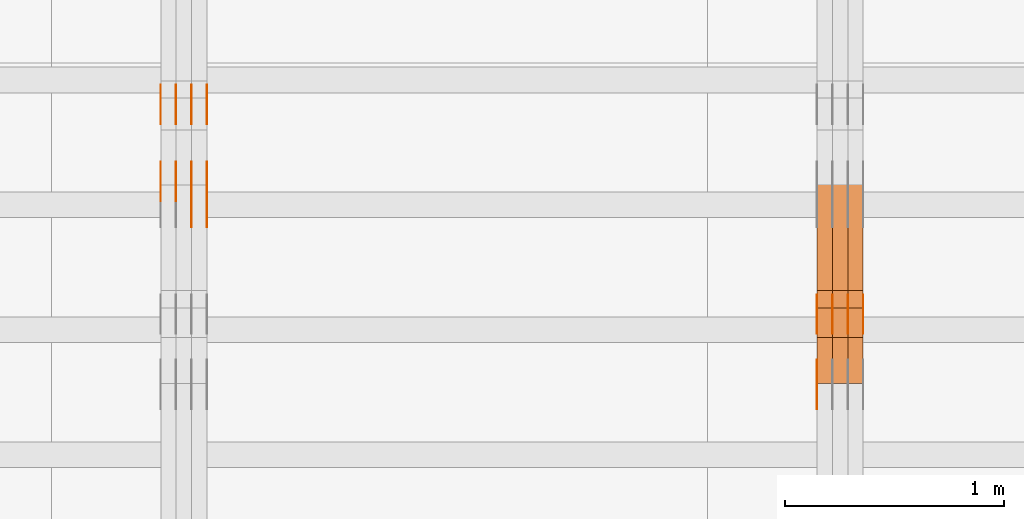
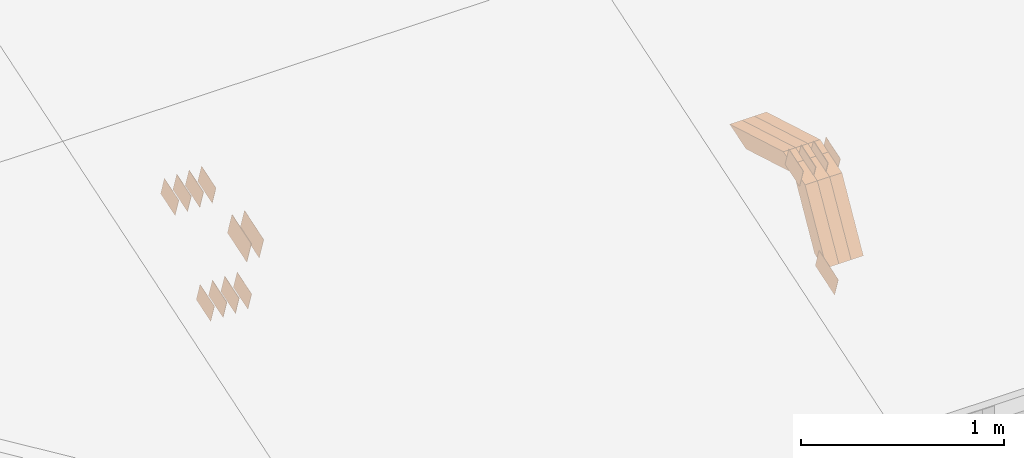
# One storey, part 249 of 385: 28 proxies.
"""IFC2X3 building model written with IfcOpenShell, lengths in millimetres."""

from ifc_helpers import new_model, entity, si_unit, converted_unit, derived_unit, direction, frame, origin, place, context, subcontext, project, spatial, polyline, outline, extrude, source, transform, mapped, material, type_object, type_shapes, element, save


model = new_model("IFC2X3")

# Units and contexts
model_context = context("Model", 3, precision=0.01, world=origin(), true_north=direction((6.12303176911189e-17, 1.0)))
body_context = subcontext(model_context, "Body", "Model", "MODEL_VIEW")
ifc_project = project(units=[si_unit("LENGTHUNIT", "METRE", prefix="MILLI"), si_unit("AREAUNIT", "SQUARE_METRE"), si_unit("VOLUMEUNIT", "CUBIC_METRE"), converted_unit("PLANEANGLEUNIT", "DEGREE", entity("IfcRatioMeasure", 0.0174532925199433), si_unit("PLANEANGLEUNIT", "RADIAN"), dimensions=[0, 0, 0, 0, 0, 0, 0]), si_unit("MASSUNIT", "GRAM", prefix="KILO"), derived_unit("MASSDENSITYUNIT", [(si_unit("MASSUNIT", "GRAM", prefix="KILO"), 1), (si_unit("LENGTHUNIT", "METRE"), -3)]), si_unit("TIMEUNIT", "SECOND"), si_unit("FREQUENCYUNIT", "HERTZ"), si_unit("THERMODYNAMICTEMPERATUREUNIT", "DEGREE_CELSIUS"), derived_unit("THERMALTRANSMITTANCEUNIT", [(si_unit("MASSUNIT", "GRAM", prefix="KILO"), 1), (si_unit("THERMODYNAMICTEMPERATUREUNIT", "KELVIN"), -1), (si_unit("TIMEUNIT", "SECOND"), -3)]), derived_unit("VOLUMETRICFLOWRATEUNIT", [(si_unit("LENGTHUNIT", "METRE"), 3), (si_unit("TIMEUNIT", "SECOND"), -1)]), si_unit("ELECTRICCURRENTUNIT", "AMPERE"), si_unit("ELECTRICVOLTAGEUNIT", "VOLT"), si_unit("POWERUNIT", "WATT"), si_unit("FORCEUNIT", "NEWTON", prefix="KILO"), si_unit("ILLUMINANCEUNIT", "LUX"), si_unit("LUMINOUSFLUXUNIT", "LUMEN"), si_unit("LUMINOUSINTENSITYUNIT", "CANDELA"), derived_unit("USERDEFINED", [(si_unit("MASSUNIT", "GRAM", prefix="KILO"), -1), (si_unit("LENGTHUNIT", "METRE"), -2), (si_unit("TIMEUNIT", "SECOND"), 3), (si_unit("LUMINOUSFLUXUNIT", "LUMEN"), 1)]), derived_unit("LINEARVELOCITYUNIT", [(si_unit("LENGTHUNIT", "METRE"), 1), (si_unit("TIMEUNIT", "SECOND"), -1)]), si_unit("PRESSUREUNIT", "PASCAL"), derived_unit("USERDEFINED", [(si_unit("LENGTHUNIT", "METRE"), -2), (si_unit("MASSUNIT", "GRAM", prefix="KILO"), 1), (si_unit("TIMEUNIT", "SECOND"), -2)])], contexts=[model_context])

# Site, building, storey
site_placement = place(None, origin())
site = spatial("IfcSite", under=ifc_project, at=site_placement, CompositionType="ELEMENT")
building_placement = place(site_placement, origin())
building = spatial("IfcBuilding", under=site, at=building_placement, CompositionType="ELEMENT")
storey_placement = place(building_placement, origin())
storey = spatial("IfcBuildingStorey", under=building, at=storey_placement, Name="Default", CompositionType="ELEMENT", Elevation=0.0)

# Proxies
ifc_material_1 = material(Name="IfcSurfaceStyle #477129")
building_element_proxy_type_1 = type_object("IfcBuildingElementProxyType", PredefinedType="NOTDEFINED", material=ifc_material_1)
shared_shape_1 = source(origin(), body_context, "Body", "SweptSolid", [
    extrude(outline(polyline([(-99.9998204243802, -60.000067376167), (99.9998338462265, -60.000067376167), (99.9998204243802, 60.000067376167), (-99.9998338462265, 60.000067376167), (-99.9998204243802, -60.000067376167)])), frame((100.000602015329, 60.0001864986889, 0.0), z_axis=(0.0, 0.0, 1.0), x_axis=(-1.0, 0.0, 0.0)), (0.0, 0.0, 1.0), 1.29999999999999),
])
type_shapes(building_element_proxy_type_1, [shared_shape_1])
proxy_1_placement = place(building_placement, frame((39175.0, 4114.85465165112, 513.097031388771), z_axis=(-1.0, 0.0, 0.0), x_axis=(0.0, 0.951056516295124, 0.309016994375039)))
element("IfcBuildingElementProxy", 1, at=proxy_1_placement, inside=storey, type_object=building_element_proxy_type_1, material=ifc_material_1, context=body_context, shape_type="MappedRepresentation", body=[
    mapped(shared_shape_1, transform((0.0, 0.0, 0.0), scale=1.0)),
])
ifc_material_2 = material(Name="IfcSurfaceStyle #470232")
building_element_proxy_type_2 = type_object("IfcBuildingElementProxyType", PredefinedType="NOTDEFINED", material=ifc_material_2)
shared_shape_2 = source(origin(), body_context, "Body", "SweptSolid", [
    extrude(outline(polyline([(-74.999865998172, -60.0000306612919), (74.999869989555, -60.0000306612919), (74.999865998172, 60.0000306612919), (-74.999869989555, 60.0000306612919), (-74.999865998172, -60.0000306612919)])), frame((75.0006726017528, 60.0001996460842, 0.0), z_axis=(0.0, 0.0, 1.0), x_axis=(-1.0, 0.0, 0.0)), (0.0, 0.0, 1.0), 1.3),
])
type_shapes(building_element_proxy_type_2, [shared_shape_2])
proxy_2_placement = place(building_placement, frame((39386.3, 4460.38978242656, 957.314497110567), z_axis=(-1.0, 0.0, 0.0), x_axis=(0.0, 0.951056516295154, 0.309016994374948)))
element("IfcBuildingElementProxy", 2, at=proxy_2_placement, inside=storey, type_object=building_element_proxy_type_2, material=ifc_material_2, context=body_context, shape_type="MappedRepresentation", body=[
    mapped(shared_shape_2, transform((0.0, 0.0, 0.0), scale=1.0)),
])
ifc_material_3 = material(Name="IfcSurfaceStyle #470175")
building_element_proxy_type_3 = type_object("IfcBuildingElementProxyType", PredefinedType="NOTDEFINED", material=ifc_material_3)
shared_shape_3 = source(origin(), body_context, "Body", "SweptSolid", [
    extrude(outline(polyline([(-74.999865998172, -60.0000306612919), (74.999869989555, -60.0000306612919), (74.999865998172, 60.0000306612919), (-74.999869989555, 60.0000306612919), (-74.999865998172, -60.0000306612919)])), frame((75.0006726017528, 60.0001996460842, 0.0), z_axis=(0.0, 0.0, 1.0), x_axis=(-1.0, 0.0, 0.0)), (0.0, 0.0, 1.0), 1.3),
])
type_shapes(building_element_proxy_type_3, [shared_shape_3])
proxy_3_placement = place(building_placement, frame((39315.0, 4460.38978242656, 957.314497110567), z_axis=(-1.0, 0.0, 0.0), x_axis=(0.0, 0.951056516295154, 0.309016994374948)))
element("IfcBuildingElementProxy", 3, at=proxy_3_placement, inside=storey, type_object=building_element_proxy_type_3, material=ifc_material_3, context=body_context, shape_type="MappedRepresentation", body=[
    mapped(shared_shape_3, transform((0.0, 0.0, 0.0), scale=1.0)),
])
ifc_material_4 = material(Name="IfcSurfaceStyle #470118")
building_element_proxy_type_4 = type_object("IfcBuildingElementProxyType", PredefinedType="NOTDEFINED", material=ifc_material_4)
shared_shape_4 = source(origin(), body_context, "Body", "SweptSolid", [
    extrude(outline(polyline([(-74.999865998172, -60.0000306612919), (74.999869989555, -60.0000306612919), (74.999865998172, 60.0000306612919), (-74.999869989555, 60.0000306612919), (-74.999865998172, -60.0000306612919)])), frame((75.0006726017528, 60.0001996460842, 0.0), z_axis=(0.0, 0.0, 1.0), x_axis=(-1.0, 0.0, 0.0)), (0.0, 0.0, 1.0), 1.3),
])
type_shapes(building_element_proxy_type_4, [shared_shape_4])
proxy_4_placement = place(building_placement, frame((39316.3, 4460.38978242656, 957.314497110567), z_axis=(-1.0, 0.0, 0.0), x_axis=(0.0, 0.951056516295154, 0.309016994374948)))
element("IfcBuildingElementProxy", 4, at=proxy_4_placement, inside=storey, type_object=building_element_proxy_type_4, material=ifc_material_4, context=body_context, shape_type="MappedRepresentation", body=[
    mapped(shared_shape_4, transform((0.0, 0.0, 0.0), scale=1.0)),
])
ifc_material_5 = material(Name="IfcSurfaceStyle #470061")
building_element_proxy_type_5 = type_object("IfcBuildingElementProxyType", PredefinedType="NOTDEFINED", material=ifc_material_5)
shared_shape_5 = source(origin(), body_context, "Body", "SweptSolid", [
    extrude(outline(polyline([(-74.999865998172, -60.0000306612919), (74.999869989555, -60.0000306612919), (74.999865998172, 60.0000306612919), (-74.999869989555, 60.0000306612919), (-74.999865998172, -60.0000306612919)])), frame((75.0006726017528, 60.0001996460842, 0.0), z_axis=(0.0, 0.0, 1.0), x_axis=(-1.0, 0.0, 0.0)), (0.0, 0.0, 1.0), 1.29999999999999),
])
type_shapes(building_element_proxy_type_5, [shared_shape_5])
proxy_5_placement = place(building_placement, frame((39245.0, 4460.38978242656, 957.314497110567), z_axis=(-1.0, 0.0, 0.0), x_axis=(0.0, 0.951056516295154, 0.309016994374948)))
element("IfcBuildingElementProxy", 5, at=proxy_5_placement, inside=storey, type_object=building_element_proxy_type_5, material=ifc_material_5, context=body_context, shape_type="MappedRepresentation", body=[
    mapped(shared_shape_5, transform((0.0, 0.0, 0.0), scale=1.0)),
])
ifc_material_6 = material(Name="IfcSurfaceStyle #470004")
building_element_proxy_type_6 = type_object("IfcBuildingElementProxyType", PredefinedType="NOTDEFINED", material=ifc_material_6)
shared_shape_6 = source(origin(), body_context, "Body", "SweptSolid", [
    extrude(outline(polyline([(-74.999865998172, -60.0000306612919), (74.999869989555, -60.0000306612919), (74.999865998172, 60.0000306612919), (-74.999869989555, 60.0000306612919), (-74.999865998172, -60.0000306612919)])), frame((75.0006726017528, 60.0001996460842, 0.0), z_axis=(0.0, 0.0, 1.0), x_axis=(-1.0, 0.0, 0.0)), (0.0, 0.0, 1.0), 1.29999999999999),
])
type_shapes(building_element_proxy_type_6, [shared_shape_6])
proxy_6_placement = place(building_placement, frame((39246.3, 4460.38978242656, 957.314497110567), z_axis=(-1.0, 0.0, 0.0), x_axis=(0.0, 0.951056516295154, 0.309016994374948)))
element("IfcBuildingElementProxy", 6, at=proxy_6_placement, inside=storey, type_object=building_element_proxy_type_6, material=ifc_material_6, context=body_context, shape_type="MappedRepresentation", body=[
    mapped(shared_shape_6, transform((0.0, 0.0, 0.0), scale=1.0)),
])
ifc_material_7 = material(Name="IfcSurfaceStyle #469947")
building_element_proxy_type_7 = type_object("IfcBuildingElementProxyType", PredefinedType="NOTDEFINED", material=ifc_material_7)
shared_shape_7 = source(origin(), body_context, "Body", "SweptSolid", [
    extrude(outline(polyline([(-74.999865998172, -60.0000306612919), (74.999869989555, -60.0000306612919), (74.999865998172, 60.0000306612919), (-74.999869989555, 60.0000306612919), (-74.999865998172, -60.0000306612919)])), frame((75.0006726017528, 60.0001996460842, 0.0), z_axis=(0.0, 0.0, 1.0), x_axis=(-1.0, 0.0, 0.0)), (0.0, 0.0, 1.0), 1.29999999999999),
])
type_shapes(building_element_proxy_type_7, [shared_shape_7])
proxy_7_placement = place(building_placement, frame((39175.0, 4460.38978242656, 957.314497110567), z_axis=(-1.0, 0.0, 0.0), x_axis=(0.0, 0.951056516295154, 0.309016994374948)))
element("IfcBuildingElementProxy", 7, at=proxy_7_placement, inside=storey, type_object=building_element_proxy_type_7, material=ifc_material_7, context=body_context, shape_type="MappedRepresentation", body=[
    mapped(shared_shape_7, transform((0.0, 0.0, 0.0), scale=1.0)),
])
ifc_material_8 = material(Name="IfcSurfaceStyle #457704")
building_element_proxy_type_8 = type_object("IfcBuildingElementProxyType", Name="T1-W12 457702", PredefinedType="NOTDEFINED", material=ifc_material_8)
shared_shape_8 = source(origin(), body_context, "Body", "SweptSolid", [
    extrude(outline(polyline([(-249.405625983165, -47.5001691155616), (243.345753908996, -47.5001691155616), (232.115534842595, 2.39993474701938e-05), (162.527010966644, 47.5001571158879), (-388.58267373507, 47.5001571158879), (-249.405625983165, -47.5001691155616)])), frame((243.345867653852, 47.5001571158879, 0.0), z_axis=(0.0, 0.0, 1.0), x_axis=(-1.0, 0.0, 0.0)), (0.0, 0.0, 1.0), 70.0),
])
type_shapes(building_element_proxy_type_8, [shared_shape_8])
proxy_8_placement = place(building_placement, frame((39385.0, 4581.32698473632, 976.172276753357), z_axis=(-1.0, 0.0, 0.0), x_axis=(0.0, 0.959722067881787, -0.280951156645966)))
element("IfcBuildingElementProxy", 8, at=proxy_8_placement, inside=storey, type_object=building_element_proxy_type_8, material=ifc_material_8, Name="T1-W12", context=body_context, shape_type="MappedRepresentation", body=[
    mapped(shared_shape_8, transform((0.0, 0.0, 0.0), scale=1.0)),
])
ifc_material_9 = material(Name="IfcSurfaceStyle #457638")
building_element_proxy_type_9 = type_object("IfcBuildingElementProxyType", Name="T1-W12 457636", PredefinedType="NOTDEFINED", material=ifc_material_9)
shared_shape_9 = source(origin(), body_context, "Body", "SweptSolid", [
    extrude(outline(polyline([(-249.405625983165, -47.5001691155616), (243.345753908996, -47.5001691155616), (232.115534842595, 2.39993474701938e-05), (162.527010966644, 47.5001571158879), (-388.58267373507, 47.5001571158879), (-249.405625983165, -47.5001691155616)])), frame((243.345867653852, 47.5001571158879, 0.0), z_axis=(0.0, 0.0, 1.0), x_axis=(-1.0, 0.0, 0.0)), (0.0, 0.0, 1.0), 70.0),
])
type_shapes(building_element_proxy_type_9, [shared_shape_9])
proxy_9_placement = place(building_placement, frame((39315.0, 4581.32698473632, 976.172276753357), z_axis=(-1.0, 0.0, 0.0), x_axis=(0.0, 0.959722067881787, -0.280951156645966)))
element("IfcBuildingElementProxy", 9, at=proxy_9_placement, inside=storey, type_object=building_element_proxy_type_9, material=ifc_material_9, Name="T1-W12", context=body_context, shape_type="MappedRepresentation", body=[
    mapped(shared_shape_9, transform((0.0, 0.0, 0.0), scale=1.0)),
])
ifc_material_10 = material(Name="IfcSurfaceStyle #457572")
building_element_proxy_type_10 = type_object("IfcBuildingElementProxyType", Name="T1-W12 457570", PredefinedType="NOTDEFINED", material=ifc_material_10)
shared_shape_10 = source(origin(), body_context, "Body", "SweptSolid", [
    extrude(outline(polyline([(-249.405625983165, -47.5001691155616), (243.345753908996, -47.5001691155616), (232.115534842595, 2.39993474701938e-05), (162.527010966644, 47.5001571158879), (-388.58267373507, 47.5001571158879), (-249.405625983165, -47.5001691155616)])), frame((243.345867653852, 47.5001571158879, 0.0), z_axis=(0.0, 0.0, 1.0), x_axis=(-1.0, 0.0, 0.0)), (0.0, 0.0, 1.0), 70.0),
])
type_shapes(building_element_proxy_type_10, [shared_shape_10])
proxy_10_placement = place(building_placement, frame((39245.0, 4581.32698473632, 976.172276753357), z_axis=(-1.0, 0.0, 0.0), x_axis=(0.0, 0.959722067881787, -0.280951156645966)))
element("IfcBuildingElementProxy", 10, at=proxy_10_placement, inside=storey, type_object=building_element_proxy_type_10, material=ifc_material_10, Name="T1-W12", context=body_context, shape_type="MappedRepresentation", body=[
    mapped(shared_shape_10, transform((0.0, 0.0, 0.0), scale=1.0)),
])
ifc_material_11 = material(Name="IfcSurfaceStyle #457308")
building_element_proxy_type_11 = type_object("IfcBuildingElementProxyType", Name="T1-W27 457306", PredefinedType="NOTDEFINED", material=ifc_material_11)
shared_shape_11 = source(origin(), body_context, "Body", "SweptSolid", [
    extrude(outline(polyline([(-321.979763159708, -47.49993999164), (138.960018341432, -47.49993999164), (191.013775341887, -0.000473170132329126), (209.87827169492, 47.5001765767061), (-217.872302218531, 47.5001765767062), (-321.979763159708, -47.49993999164)])), frame((209.87827169492, 47.5001765767061, 0.0), z_axis=(0.0, 0.0, 1.0), x_axis=(-1.0, 0.0, 0.0)), (0.0, 0.0, 1.0), 70.0),
])
type_shapes(building_element_proxy_type_11, [shared_shape_11])
proxy_11_placement = place(building_placement, frame((39385.0, 4233.3125, 512.021728515625), z_axis=(-1.0, 0.0, 0.0), x_axis=(0.0, 0.494231057369727, 0.869330582650352)))
element("IfcBuildingElementProxy", 11, at=proxy_11_placement, inside=storey, type_object=building_element_proxy_type_11, material=ifc_material_11, Name="T1-W27", context=body_context, shape_type="MappedRepresentation", body=[
    mapped(shared_shape_11, transform((0.0, 0.0, 0.0), scale=1.0)),
])
ifc_material_12 = material(Name="IfcSurfaceStyle #457242")
building_element_proxy_type_12 = type_object("IfcBuildingElementProxyType", Name="T1-W27 457240", PredefinedType="NOTDEFINED", material=ifc_material_12)
shared_shape_12 = source(origin(), body_context, "Body", "SweptSolid", [
    extrude(outline(polyline([(-321.979763159708, -47.49993999164), (138.960018341432, -47.49993999164), (191.013775341887, -0.000473170132329126), (209.87827169492, 47.5001765767061), (-217.872302218531, 47.5001765767062), (-321.979763159708, -47.49993999164)])), frame((209.87827169492, 47.5001765767061, 0.0), z_axis=(0.0, 0.0, 1.0), x_axis=(-1.0, 0.0, 0.0)), (0.0, 0.0, 1.0), 70.0),
])
type_shapes(building_element_proxy_type_12, [shared_shape_12])
proxy_12_placement = place(building_placement, frame((39315.0, 4233.3125, 512.021728515625), z_axis=(-1.0, 0.0, 0.0), x_axis=(0.0, 0.494231057369727, 0.869330582650352)))
element("IfcBuildingElementProxy", 12, at=proxy_12_placement, inside=storey, type_object=building_element_proxy_type_12, material=ifc_material_12, Name="T1-W27", context=body_context, shape_type="MappedRepresentation", body=[
    mapped(shared_shape_12, transform((0.0, 0.0, 0.0), scale=1.0)),
])
ifc_material_13 = material(Name="IfcSurfaceStyle #457176")
building_element_proxy_type_13 = type_object("IfcBuildingElementProxyType", Name="T1-W27 457174", PredefinedType="NOTDEFINED", material=ifc_material_13)
shared_shape_13 = source(origin(), body_context, "Body", "SweptSolid", [
    extrude(outline(polyline([(-321.979763159708, -47.49993999164), (138.960018341432, -47.49993999164), (191.013775341887, -0.000473170132329126), (209.87827169492, 47.5001765767061), (-217.872302218531, 47.5001765767062), (-321.979763159708, -47.49993999164)])), frame((209.87827169492, 47.5001765767061, 0.0), z_axis=(0.0, 0.0, 1.0), x_axis=(-1.0, 0.0, 0.0)), (0.0, 0.0, 1.0), 70.0),
])
type_shapes(building_element_proxy_type_13, [shared_shape_13])
proxy_13_placement = place(building_placement, frame((39245.0, 4233.3125, 512.021728515625), z_axis=(-1.0, 0.0, 0.0), x_axis=(0.0, 0.494231057369727, 0.869330582650352)))
element("IfcBuildingElementProxy", 13, at=proxy_13_placement, inside=storey, type_object=building_element_proxy_type_13, material=ifc_material_13, Name="T1-W27", context=body_context, shape_type="MappedRepresentation", body=[
    mapped(shared_shape_13, transform((0.0, 0.0, 0.0), scale=1.0)),
])
ifc_material_14 = material(Name="IfcSurfaceStyle #442640")
building_element_proxy_type_14 = type_object("IfcBuildingElementProxyType", PredefinedType="NOTDEFINED", material=ifc_material_14)
shared_shape_14 = source(origin(), body_context, "Body", "SweptSolid", [
    extrude(outline(polyline([(-74.9998707133927, -60.0000596852269), (74.9998841352353, -60.0000596852269), (74.999861282944, 60.0000596852269), (-74.9998747047866, 60.0000596852269), (-74.9998707133927, -60.0000596852269)])), frame((74.9998841352353, 60.0000596852269, 0.0), z_axis=(0.0, 0.0, 1.0), x_axis=(-1.0, 0.0, 0.0)), (0.0, 0.0, 1.0), 1.3),
])
type_shapes(building_element_proxy_type_14, [shared_shape_14])
proxy_14_placement = place(building_placement, frame((36386.3, 5067.4882362875, 826.131473120182), z_axis=(-1.0, 0.0, 0.0), x_axis=(0.0, 0.951056516295124, 0.309016994375039)))
element("IfcBuildingElementProxy", 14, at=proxy_14_placement, inside=storey, type_object=building_element_proxy_type_14, material=ifc_material_14, context=body_context, shape_type="MappedRepresentation", body=[
    mapped(shared_shape_14, transform((0.0, 0.0, 0.0), scale=1.0)),
])
ifc_material_15 = material(Name="IfcSurfaceStyle #442583")
building_element_proxy_type_15 = type_object("IfcBuildingElementProxyType", PredefinedType="NOTDEFINED", material=ifc_material_15)
shared_shape_15 = source(origin(), body_context, "Body", "SweptSolid", [
    extrude(outline(polyline([(-74.9998707133927, -60.0000596852269), (74.9998841352353, -60.0000596852269), (74.999861282944, 60.0000596852269), (-74.9998747047866, 60.0000596852269), (-74.9998707133927, -60.0000596852269)])), frame((74.9998841352353, 60.0000596852269, 0.0), z_axis=(0.0, 0.0, 1.0), x_axis=(-1.0, 0.0, 0.0)), (0.0, 0.0, 1.0), 1.3),
])
type_shapes(building_element_proxy_type_15, [shared_shape_15])
proxy_15_placement = place(building_placement, frame((36315.0, 5067.4882362875, 826.131473120182), z_axis=(-1.0, 0.0, 0.0), x_axis=(0.0, 0.951056516295124, 0.309016994375039)))
element("IfcBuildingElementProxy", 15, at=proxy_15_placement, inside=storey, type_object=building_element_proxy_type_15, material=ifc_material_15, context=body_context, shape_type="MappedRepresentation", body=[
    mapped(shared_shape_15, transform((0.0, 0.0, 0.0), scale=1.0)),
])
ifc_material_16 = material(Name="IfcSurfaceStyle #442526")
building_element_proxy_type_16 = type_object("IfcBuildingElementProxyType", PredefinedType="NOTDEFINED", material=ifc_material_16)
shared_shape_16 = source(origin(), body_context, "Body", "SweptSolid", [
    extrude(outline(polyline([(-74.9998707133927, -60.0000596852269), (74.9998841352353, -60.0000596852269), (74.999861282944, 60.0000596852269), (-74.9998747047866, 60.0000596852269), (-74.9998707133927, -60.0000596852269)])), frame((74.9998841352353, 60.0000596852269, 0.0), z_axis=(0.0, 0.0, 1.0), x_axis=(-1.0, 0.0, 0.0)), (0.0, 0.0, 1.0), 1.3),
])
type_shapes(building_element_proxy_type_16, [shared_shape_16])
proxy_16_placement = place(building_placement, frame((36316.3, 5067.4882362875, 826.131473120182), z_axis=(-1.0, 0.0, 0.0), x_axis=(0.0, 0.951056516295124, 0.309016994375039)))
element("IfcBuildingElementProxy", 16, at=proxy_16_placement, inside=storey, type_object=building_element_proxy_type_16, material=ifc_material_16, context=body_context, shape_type="MappedRepresentation", body=[
    mapped(shared_shape_16, transform((0.0, 0.0, 0.0), scale=1.0)),
])
ifc_material_17 = material(Name="IfcSurfaceStyle #442469")
building_element_proxy_type_17 = type_object("IfcBuildingElementProxyType", PredefinedType="NOTDEFINED", material=ifc_material_17)
shared_shape_17 = source(origin(), body_context, "Body", "SweptSolid", [
    extrude(outline(polyline([(-74.9998707133927, -60.0000596852269), (74.9998841352353, -60.0000596852269), (74.999861282944, 60.0000596852269), (-74.9998747047866, 60.0000596852269), (-74.9998707133927, -60.0000596852269)])), frame((74.9998841352353, 60.0000596852269, 0.0), z_axis=(0.0, 0.0, 1.0), x_axis=(-1.0, 0.0, 0.0)), (0.0, 0.0, 1.0), 1.29999999999999),
])
type_shapes(building_element_proxy_type_17, [shared_shape_17])
proxy_17_placement = place(building_placement, frame((36245.0, 5067.4882362875, 826.131473120182), z_axis=(-1.0, 0.0, 0.0), x_axis=(0.0, 0.951056516295124, 0.309016994375039)))
element("IfcBuildingElementProxy", 17, at=proxy_17_placement, inside=storey, type_object=building_element_proxy_type_17, material=ifc_material_17, context=body_context, shape_type="MappedRepresentation", body=[
    mapped(shared_shape_17, transform((0.0, 0.0, 0.0), scale=1.0)),
])
ifc_material_18 = material(Name="IfcSurfaceStyle #442412")
building_element_proxy_type_18 = type_object("IfcBuildingElementProxyType", PredefinedType="NOTDEFINED", material=ifc_material_18)
shared_shape_18 = source(origin(), body_context, "Body", "SweptSolid", [
    extrude(outline(polyline([(-74.9998707133927, -60.0000596852269), (74.9998841352353, -60.0000596852269), (74.999861282944, 60.0000596852269), (-74.9998747047866, 60.0000596852269), (-74.9998707133927, -60.0000596852269)])), frame((74.9998841352353, 60.0000596852269, 0.0), z_axis=(0.0, 0.0, 1.0), x_axis=(-1.0, 0.0, 0.0)), (0.0, 0.0, 1.0), 1.29999999999999),
])
type_shapes(building_element_proxy_type_18, [shared_shape_18])
proxy_18_placement = place(building_placement, frame((36246.3, 5067.4882362875, 826.131473120182), z_axis=(-1.0, 0.0, 0.0), x_axis=(0.0, 0.951056516295124, 0.309016994375039)))
element("IfcBuildingElementProxy", 18, at=proxy_18_placement, inside=storey, type_object=building_element_proxy_type_18, material=ifc_material_18, context=body_context, shape_type="MappedRepresentation", body=[
    mapped(shared_shape_18, transform((0.0, 0.0, 0.0), scale=1.0)),
])
ifc_material_19 = material(Name="IfcSurfaceStyle #442355")
building_element_proxy_type_19 = type_object("IfcBuildingElementProxyType", PredefinedType="NOTDEFINED", material=ifc_material_19)
shared_shape_19 = source(origin(), body_context, "Body", "SweptSolid", [
    extrude(outline(polyline([(-74.9998707133927, -60.0000596852269), (74.9998841352353, -60.0000596852269), (74.999861282944, 60.0000596852269), (-74.9998747047866, 60.0000596852269), (-74.9998707133927, -60.0000596852269)])), frame((74.9998841352353, 60.0000596852269, 0.0), z_axis=(0.0, 0.0, 1.0), x_axis=(-1.0, 0.0, 0.0)), (0.0, 0.0, 1.0), 1.29999999999999),
])
type_shapes(building_element_proxy_type_19, [shared_shape_19])
proxy_19_placement = place(building_placement, frame((36175.0, 5067.4882362875, 826.131473120182), z_axis=(-1.0, 0.0, 0.0), x_axis=(0.0, 0.951056516295124, 0.309016994375039)))
element("IfcBuildingElementProxy", 19, at=proxy_19_placement, inside=storey, type_object=building_element_proxy_type_19, material=ifc_material_19, context=body_context, shape_type="MappedRepresentation", body=[
    mapped(shared_shape_19, transform((0.0, 0.0, 0.0), scale=1.0)),
])
ifc_material_20 = material(Name="IfcSurfaceStyle #436826")
building_element_proxy_type_20 = type_object("IfcBuildingElementProxyType", PredefinedType="NOTDEFINED", material=ifc_material_20)
shared_shape_20 = source(origin(), body_context, "Body", "SweptSolid", [
    extrude(outline(polyline([(-74.9998565677224, -60.0000596852342), (74.9998794200083, -60.0000596852342), (74.9998565677242, 60.0000596852342), (-74.9998794200101, 60.0000596852342), (-74.9998565677224, -60.0000596852342)])), frame((74.9998794200083, 60.0000596852342, 0.0), z_axis=(0.0, 0.0, 1.0), x_axis=(-1.0, 0.0, 0.0)), (0.0, 0.0, 1.0), 1.3),
])
type_shapes(building_element_proxy_type_20, [shared_shape_20])
proxy_20_placement = place(building_placement, frame((36386.3, 5418.6991737875, 1250.81341892098), z_axis=(-1.0, 0.0, 0.0), x_axis=(0.0, 0.951056516295154, 0.309016994374948)))
element("IfcBuildingElementProxy", 20, at=proxy_20_placement, inside=storey, type_object=building_element_proxy_type_20, material=ifc_material_20, context=body_context, shape_type="MappedRepresentation", body=[
    mapped(shared_shape_20, transform((0.0, 0.0, 0.0), scale=1.0)),
])
ifc_material_21 = material(Name="IfcSurfaceStyle #436769")
building_element_proxy_type_21 = type_object("IfcBuildingElementProxyType", PredefinedType="NOTDEFINED", material=ifc_material_21)
shared_shape_21 = source(origin(), body_context, "Body", "SweptSolid", [
    extrude(outline(polyline([(-74.9998565677224, -60.0000596852342), (74.9998794200083, -60.0000596852342), (74.9998565677242, 60.0000596852342), (-74.9998794200101, 60.0000596852342), (-74.9998565677224, -60.0000596852342)])), frame((74.9998794200083, 60.0000596852342, 0.0), z_axis=(0.0, 0.0, 1.0), x_axis=(-1.0, 0.0, 0.0)), (0.0, 0.0, 1.0), 1.3),
])
type_shapes(building_element_proxy_type_21, [shared_shape_21])
proxy_21_placement = place(building_placement, frame((36315.0, 5418.6991737875, 1250.81341892098), z_axis=(-1.0, 0.0, 0.0), x_axis=(0.0, 0.951056516295154, 0.309016994374948)))
element("IfcBuildingElementProxy", 21, at=proxy_21_placement, inside=storey, type_object=building_element_proxy_type_21, material=ifc_material_21, context=body_context, shape_type="MappedRepresentation", body=[
    mapped(shared_shape_21, transform((0.0, 0.0, 0.0), scale=1.0)),
])
ifc_material_22 = material(Name="IfcSurfaceStyle #436712")
building_element_proxy_type_22 = type_object("IfcBuildingElementProxyType", PredefinedType="NOTDEFINED", material=ifc_material_22)
shared_shape_22 = source(origin(), body_context, "Body", "SweptSolid", [
    extrude(outline(polyline([(-74.9998565677224, -60.0000596852342), (74.9998794200083, -60.0000596852342), (74.9998565677242, 60.0000596852342), (-74.9998794200101, 60.0000596852342), (-74.9998565677224, -60.0000596852342)])), frame((74.9998794200083, 60.0000596852342, 0.0), z_axis=(0.0, 0.0, 1.0), x_axis=(-1.0, 0.0, 0.0)), (0.0, 0.0, 1.0), 1.3),
])
type_shapes(building_element_proxy_type_22, [shared_shape_22])
proxy_22_placement = place(building_placement, frame((36316.3, 5418.6991737875, 1250.81341892098), z_axis=(-1.0, 0.0, 0.0), x_axis=(0.0, 0.951056516295154, 0.309016994374948)))
element("IfcBuildingElementProxy", 22, at=proxy_22_placement, inside=storey, type_object=building_element_proxy_type_22, material=ifc_material_22, context=body_context, shape_type="MappedRepresentation", body=[
    mapped(shared_shape_22, transform((0.0, 0.0, 0.0), scale=1.0)),
])
ifc_material_23 = material(Name="IfcSurfaceStyle #436655")
building_element_proxy_type_23 = type_object("IfcBuildingElementProxyType", PredefinedType="NOTDEFINED", material=ifc_material_23)
shared_shape_23 = source(origin(), body_context, "Body", "SweptSolid", [
    extrude(outline(polyline([(-74.9998565677224, -60.0000596852342), (74.9998794200083, -60.0000596852342), (74.9998565677242, 60.0000596852342), (-74.9998794200101, 60.0000596852342), (-74.9998565677224, -60.0000596852342)])), frame((74.9998794200083, 60.0000596852342, 0.0), z_axis=(0.0, 0.0, 1.0), x_axis=(-1.0, 0.0, 0.0)), (0.0, 0.0, 1.0), 1.29999999999999),
])
type_shapes(building_element_proxy_type_23, [shared_shape_23])
proxy_23_placement = place(building_placement, frame((36245.0, 5418.6991737875, 1250.81341892098), z_axis=(-1.0, 0.0, 0.0), x_axis=(0.0, 0.951056516295154, 0.309016994374948)))
element("IfcBuildingElementProxy", 23, at=proxy_23_placement, inside=storey, type_object=building_element_proxy_type_23, material=ifc_material_23, context=body_context, shape_type="MappedRepresentation", body=[
    mapped(shared_shape_23, transform((0.0, 0.0, 0.0), scale=1.0)),
])
ifc_material_24 = material(Name="IfcSurfaceStyle #436598")
building_element_proxy_type_24 = type_object("IfcBuildingElementProxyType", PredefinedType="NOTDEFINED", material=ifc_material_24)
shared_shape_24 = source(origin(), body_context, "Body", "SweptSolid", [
    extrude(outline(polyline([(-74.9998565677224, -60.0000596852342), (74.9998794200083, -60.0000596852342), (74.9998565677242, 60.0000596852342), (-74.9998794200101, 60.0000596852342), (-74.9998565677224, -60.0000596852342)])), frame((74.9998794200083, 60.0000596852342, 0.0), z_axis=(0.0, 0.0, 1.0), x_axis=(-1.0, 0.0, 0.0)), (0.0, 0.0, 1.0), 1.29999999999999),
])
type_shapes(building_element_proxy_type_24, [shared_shape_24])
proxy_24_placement = place(building_placement, frame((36246.3, 5418.6991737875, 1250.81341892098), z_axis=(-1.0, 0.0, 0.0), x_axis=(0.0, 0.951056516295154, 0.309016994374948)))
element("IfcBuildingElementProxy", 24, at=proxy_24_placement, inside=storey, type_object=building_element_proxy_type_24, material=ifc_material_24, context=body_context, shape_type="MappedRepresentation", body=[
    mapped(shared_shape_24, transform((0.0, 0.0, 0.0), scale=1.0)),
])
ifc_material_25 = material(Name="IfcSurfaceStyle #436541")
building_element_proxy_type_25 = type_object("IfcBuildingElementProxyType", PredefinedType="NOTDEFINED", material=ifc_material_25)
shared_shape_25 = source(origin(), body_context, "Body", "SweptSolid", [
    extrude(outline(polyline([(-74.9998565677224, -60.0000596852342), (74.9998794200083, -60.0000596852342), (74.9998565677242, 60.0000596852342), (-74.9998794200101, 60.0000596852342), (-74.9998565677224, -60.0000596852342)])), frame((74.9998794200083, 60.0000596852342, 0.0), z_axis=(0.0, 0.0, 1.0), x_axis=(-1.0, 0.0, 0.0)), (0.0, 0.0, 1.0), 1.29999999999999),
])
type_shapes(building_element_proxy_type_25, [shared_shape_25])
proxy_25_placement = place(building_placement, frame((36175.0, 5418.6991737875, 1250.81341892098), z_axis=(-1.0, 0.0, 0.0), x_axis=(0.0, 0.951056516295154, 0.309016994374948)))
element("IfcBuildingElementProxy", 25, at=proxy_25_placement, inside=storey, type_object=building_element_proxy_type_25, material=ifc_material_25, context=body_context, shape_type="MappedRepresentation", body=[
    mapped(shared_shape_25, transform((0.0, 0.0, 0.0), scale=1.0)),
])
ifc_material_26 = material(Name="IfcSurfaceStyle #433406")
building_element_proxy_type_26 = type_object("IfcBuildingElementProxyType", PredefinedType="NOTDEFINED", material=ifc_material_26)
shared_shape_26 = source(origin(), body_context, "Body", "SweptSolid", [
    extrude(outline(polyline([(-99.9996257846169, -71.999973710258), (100.000009625089, -71.999973710258), (99.9996257846187, 71.999973710258), (-100.000009625091, 71.999973710258), (-99.9996257846169, -71.999973710258)])), frame((100.000083496635, 72.0000008245779, 0.0), z_axis=(0.0, 0.0, 1.0), x_axis=(-1.0, 0.0, 0.0)), (0.0, 0.0, 1.0), 1.3),
])
type_shapes(building_element_proxy_type_26, [shared_shape_26])
proxy_26_placement = place(building_placement, frame((36386.3, 4947.73195917316, 1225.53937157357), z_axis=(-1.0, 0.0, 0.0), x_axis=(0.0, 0.951056516295154, 0.309016994374948)))
element("IfcBuildingElementProxy", 26, at=proxy_26_placement, inside=storey, type_object=building_element_proxy_type_26, material=ifc_material_26, context=body_context, shape_type="MappedRepresentation", body=[
    mapped(shared_shape_26, transform((0.0, 0.0, 0.0), scale=1.0)),
])
ifc_material_27 = material(Name="IfcSurfaceStyle #433349")
building_element_proxy_type_27 = type_object("IfcBuildingElementProxyType", PredefinedType="NOTDEFINED", material=ifc_material_27)
shared_shape_27 = source(origin(), body_context, "Body", "SweptSolid", [
    extrude(outline(polyline([(-99.9996257846169, -71.999973710258), (100.000009625089, -71.999973710258), (99.9996257846187, 71.999973710258), (-100.000009625091, 71.999973710258), (-99.9996257846169, -71.999973710258)])), frame((100.000083496635, 72.0000008245779, 0.0), z_axis=(0.0, 0.0, 1.0), x_axis=(-1.0, 0.0, 0.0)), (0.0, 0.0, 1.0), 1.3),
])
type_shapes(building_element_proxy_type_27, [shared_shape_27])
proxy_27_placement = place(building_placement, frame((36315.0, 4947.73195917316, 1225.53937157357), z_axis=(-1.0, 0.0, 0.0), x_axis=(0.0, 0.951056516295154, 0.309016994374948)))
element("IfcBuildingElementProxy", 27, at=proxy_27_placement, inside=storey, type_object=building_element_proxy_type_27, material=ifc_material_27, context=body_context, shape_type="MappedRepresentation", body=[
    mapped(shared_shape_27, transform((0.0, 0.0, 0.0), scale=1.0)),
])
ifc_material_28 = material(Name="IfcSurfaceStyle #433292")
building_element_proxy_type_28 = type_object("IfcBuildingElementProxyType", PredefinedType="NOTDEFINED", material=ifc_material_28)
shared_shape_28 = source(origin(), body_context, "Body", "SweptSolid", [
    extrude(outline(polyline([(-99.9996257846169, -71.999973710258), (100.000009625089, -71.999973710258), (99.9996257846187, 71.999973710258), (-100.000009625091, 71.999973710258), (-99.9996257846169, -71.999973710258)])), frame((100.000083496635, 72.0000008245779, 0.0), z_axis=(0.0, 0.0, 1.0), x_axis=(-1.0, 0.0, 0.0)), (0.0, 0.0, 1.0), 1.3),
])
type_shapes(building_element_proxy_type_28, [shared_shape_28])
proxy_28_placement = place(building_placement, frame((36316.3, 4947.73195917316, 1225.53937157357), z_axis=(-1.0, 0.0, 0.0), x_axis=(0.0, 0.951056516295154, 0.309016994374948)))
element("IfcBuildingElementProxy", 28, at=proxy_28_placement, inside=storey, type_object=building_element_proxy_type_28, material=ifc_material_28, context=body_context, shape_type="MappedRepresentation", body=[
    mapped(shared_shape_28, transform((0.0, 0.0, 0.0), scale=1.0)),
])

save(model, "model.ifc")
